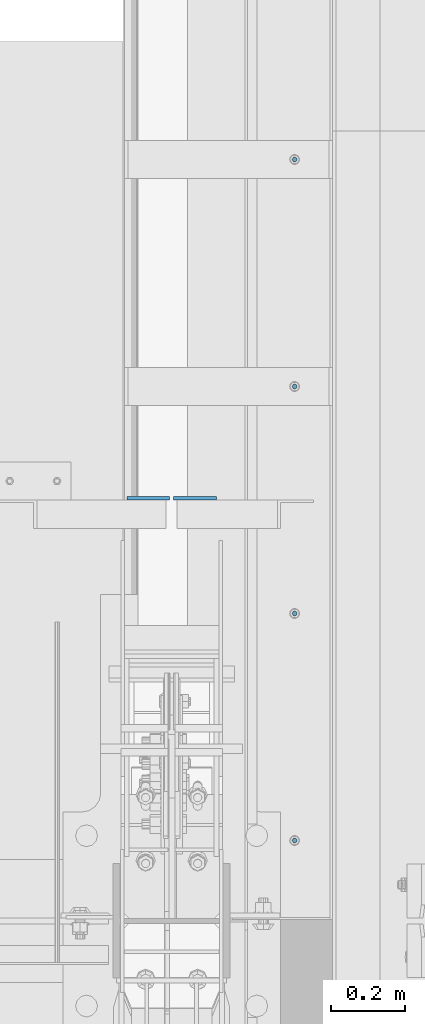
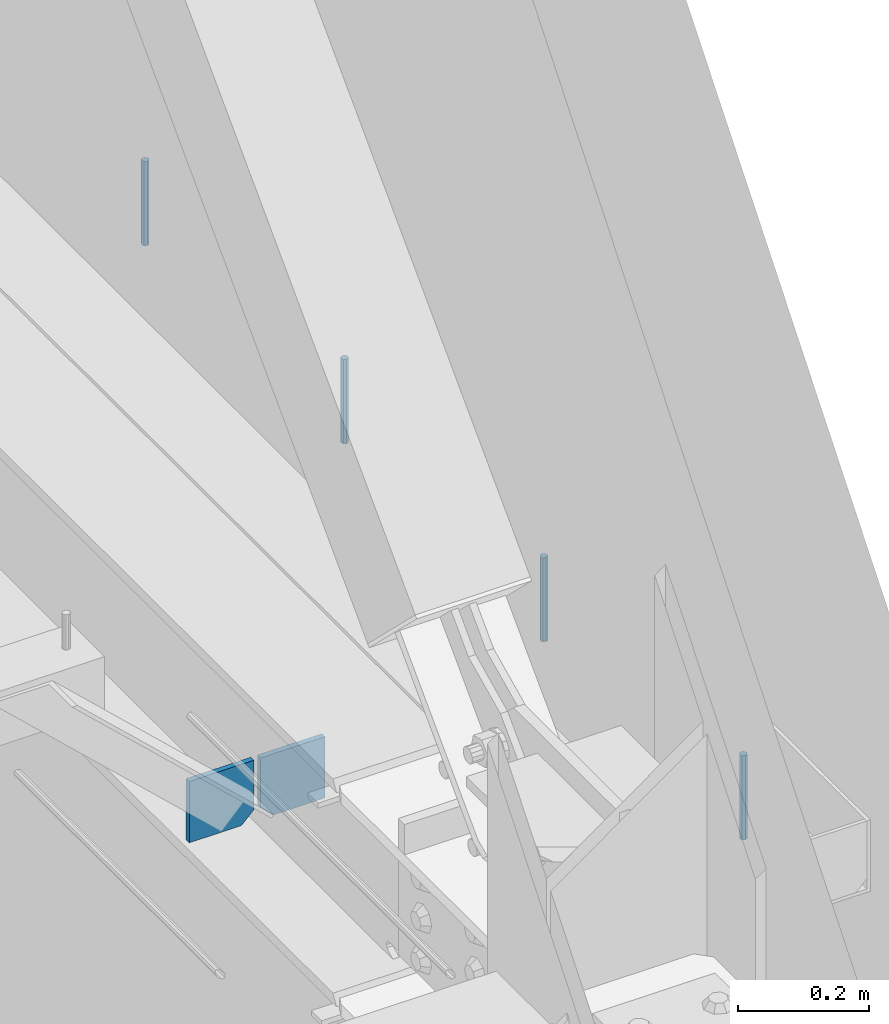
# One storey, part 409 of 1179: 6 columns, 1 element without a shape of its own.
"""IFC2X3 building model written with IfcOpenShell, lengths in millimetres."""

from ifc_helpers import new_model, si_unit, frame, origin_with_axes, place, context, subcontext, project, spatial, faceted_brep, material, type_object, element, aggregate, save


model = new_model("IFC2X3")

# Units and contexts
model_context = context("Model", 3, precision=1e-05, world=origin_with_axes())
body_context = subcontext(model_context, "Body", "Model", "MODEL_VIEW")
ifc_project = project(units=[si_unit("LENGTHUNIT", "METRE", prefix="MILLI"), si_unit("AREAUNIT", "SQUARE_METRE"), si_unit("VOLUMEUNIT", "CUBIC_METRE"), si_unit("MASSUNIT", "GRAM", prefix="KILO"), si_unit("TIMEUNIT", "SECOND"), si_unit("PLANEANGLEUNIT", "RADIAN"), si_unit("SOLIDANGLEUNIT", "STERADIAN"), si_unit("THERMODYNAMICTEMPERATUREUNIT", "DEGREE_CELSIUS"), si_unit("LUMINOUSINTENSITYUNIT", "LUMEN")], contexts=[model_context])

# Site, building, storey
site_placement = place(None, origin_with_axes())
site = spatial("IfcSite", under=ifc_project, at=site_placement, CompositionType="ELEMENT")
building_placement = place(site_placement, origin_with_axes())
building = spatial("IfcBuilding", under=site, at=building_placement, Name="Undefined", CompositionType="ELEMENT")
storey_placement = place(building_placement, origin_with_axes())
storey = spatial("IfcBuildingStorey", under=building, at=storey_placement, Name="Undefined", CompositionType="ELEMENT", Elevation=0.0)

# Assembly, columns
assembly_placement = place(storey_placement, origin_with_axes())
assembly = element("IfcElementAssembly", 1, at=assembly_placement, inside=storey, Name="BEAM", AssemblyPlace="NOTDEFINED", PredefinedType="RIGID_FRAME")
ifc_material_1 = material(Name="STEEL/A36")
column_type_1 = type_object("IfcColumnType", PredefinedType="NOTDEFINED")
column_1_placement = place(assembly_placement, frame((24245.09375, 12615.8625, 3702.05), z_axis=(1.0, 0.0, 0.0), x_axis=(0.0, 0.0, 1.0)))
column_1 = element("IfcColumn", 2, at=column_1_placement, type_object=column_type_1, material=ifc_material_1, Name="PLATE", context=body_context, shape_type="Brep", body=[
    faceted_brep([(22.2250000000004, 4.76250000000073, 57.1500000000015), (0.0, 4.76250000000073, 34.9249999999993), (0.0, -4.76250000000073, 34.9249999999993), (22.2250000000004, -4.76250000000073, 57.1500000000015), (114.300000000001, 4.76250000000073, 57.1500000000015), (114.300000000001, 4.76250000000073, -57.1500000000015), (0.0, 4.76250000000073, -57.1500000000015), (114.300000000001, -4.76250000000073, 57.1500000000015), (0.0, -4.76250000000073, -57.1500000000015), (114.300000000001, -4.76250000000073, -57.1500000000015)], [[[0, 1, 2, 3]], [[4, 5, 6, 1, 0]], [[7, 4, 0, 3]], [[8, 9, 7, 3, 2]], [[8, 6, 5, 9]], [[7, 9, 5, 4]], [[6, 8, 2, 1]]]),
])
column_2_placement = place(assembly_placement, frame((24370.50625, 12615.8625, 3702.05), z_axis=(-1.0, 0.0, 0.0), x_axis=(0.0, 0.0, 1.0)))
column_2 = element("IfcColumn", 3, at=column_2_placement, type_object=column_type_1, material=ifc_material_1, Name="PLATE", context=body_context, shape_type="Brep", body=[
    faceted_brep([(22.2250000000004, 4.76250000000073, 57.1500000000015), (0.0, 4.76250000000073, 34.9249999999993), (0.0, -4.76250000000073, 34.9249999999993), (22.2250000000004, -4.76250000000073, 57.1500000000015), (114.300000000001, 4.76250000000073, 57.1500000000015), (114.300000000001, 4.76250000000073, -57.1500000000015), (0.0, 4.76250000000073, -57.1500000000015), (114.300000000001, -4.76250000000073, 57.1500000000015), (0.0, -4.76250000000073, -57.1500000000015), (114.300000000001, -4.76250000000073, -57.1500000000015)], [[[0, 1, 2, 3]], [[4, 5, 6, 1, 0]], [[7, 4, 0, 3]], [[8, 9, 7, 3, 2]], [[8, 6, 5, 9]], [[7, 9, 5, 4]], [[6, 8, 2, 1]]]),
])
ifc_material_2 = material(Name="STEEL/A307")
column_type_2 = type_object("IfcColumnType", PredefinedType="NOTDEFINED")
column_3_placement = place(assembly_placement, frame((24638.0, 13525.5, 4108.45), z_axis=(0.0, 1.0, 0.0), x_axis=(0.0, 0.0, 1.0)))
column_3 = element("IfcColumn", 4, at=column_3_placement, type_object=column_type_2, material=ifc_material_2, Name="THREADED ROD", context=body_context, shape_type="Brep", body=[
    faceted_brep([(0.0, -6.34999999999854, 0.0), (0.0, -4.49012806053361, -4.49012806053452), (157.162499999999, -4.49012806053361, -4.49012806053361), (157.162499999999, -6.34999999999854, 0.0), (0.0, 0.0, -6.34999999999991), (157.162499999999, 0.0, -6.34999999999854), (0.0, 4.49012806053361, -4.49012806053452), (157.162499999999, 4.49012806053361, -4.49012806053361), (0.0, 6.34999999999854, 0.0), (157.162499999999, 6.34999999999854, 0.0), (0.0, 4.49012806053361, 4.49012806053452), (157.162499999999, 4.49012806053361, 4.49012806053361), (0.0, 0.0, 6.34999999999991), (157.162499999999, 0.0, 6.34999999999854), (0.0, -4.49012806053361, 4.49012806053452), (157.162499999999, -4.49012806053361, 4.49012806053361)], [[[0, 1, 2, 3]], [[1, 4, 5, 2]], [[4, 6, 7, 5]], [[6, 8, 9, 7]], [[8, 10, 11, 9]], [[10, 12, 13, 11]], [[12, 14, 15, 13]], [[14, 0, 3, 15]], [[5, 7, 9, 11, 13, 15, 3, 2]], [[14, 12, 10, 8, 6, 4, 1, 0]]]),
])
column_4_placement = place(assembly_placement, frame((24638.0, 12915.9, 4108.45), z_axis=(0.0, 1.0, 0.0), x_axis=(0.0, 0.0, 1.0)))
column_4 = element("IfcColumn", 5, at=column_4_placement, type_object=column_type_2, material=ifc_material_2, Name="THREADED ROD", context=body_context, shape_type="Brep", body=[
    faceted_brep([(0.0, -6.34999999999854, 0.0), (0.0, -4.49012806053361, -4.49012806053452), (157.162499999999, -4.49012806053361, -4.49012806053361), (157.162499999999, -6.34999999999854, 0.0), (0.0, 0.0, -6.34999999999991), (157.162499999999, 0.0, -6.34999999999854), (0.0, 4.49012806053361, -4.49012806053452), (157.162499999999, 4.49012806053361, -4.49012806053361), (0.0, 6.34999999999854, 0.0), (157.162499999999, 6.34999999999854, 0.0), (0.0, 4.49012806053361, 4.49012806053452), (157.162499999999, 4.49012806053361, 4.49012806053361), (0.0, 0.0, 6.34999999999991), (157.162499999999, 0.0, 6.34999999999854), (0.0, -4.49012806053361, 4.49012806053452), (157.162499999999, -4.49012806053361, 4.49012806053361)], [[[0, 1, 2, 3]], [[1, 4, 5, 2]], [[4, 6, 7, 5]], [[6, 8, 9, 7]], [[8, 10, 11, 9]], [[10, 12, 13, 11]], [[12, 14, 15, 13]], [[14, 0, 3, 15]], [[5, 7, 9, 11, 13, 15, 3, 2]], [[14, 12, 10, 8, 6, 4, 1, 0]]]),
])
column_5_placement = place(assembly_placement, frame((24638.0, 12306.3, 4108.45), z_axis=(0.0, 1.0, 0.0), x_axis=(0.0, 0.0, 1.0)))
column_5 = element("IfcColumn", 6, at=column_5_placement, type_object=column_type_2, material=ifc_material_2, Name="THREADED ROD", context=body_context, shape_type="Brep", body=[
    faceted_brep([(0.0, -6.34999999999854, 0.0), (0.0, -4.49012806053361, -4.49012806053452), (157.162499999999, -4.49012806053361, -4.49012806053361), (157.162499999999, -6.34999999999854, 0.0), (0.0, 0.0, -6.34999999999991), (157.162499999999, 0.0, -6.34999999999854), (0.0, 4.49012806053361, -4.49012806053452), (157.162499999999, 4.49012806053361, -4.49012806053361), (0.0, 6.34999999999854, 0.0), (157.162499999999, 6.34999999999854, 0.0), (0.0, 4.49012806053361, 4.49012806053452), (157.162499999999, 4.49012806053361, 4.49012806053361), (0.0, 0.0, 6.34999999999991), (157.162499999999, 0.0, 6.34999999999854), (0.0, -4.49012806053361, 4.49012806053452), (157.162499999999, -4.49012806053361, 4.49012806053361)], [[[0, 1, 2, 3]], [[1, 4, 5, 2]], [[4, 6, 7, 5]], [[6, 8, 9, 7]], [[8, 10, 11, 9]], [[10, 12, 13, 11]], [[12, 14, 15, 13]], [[14, 0, 3, 15]], [[5, 7, 9, 11, 13, 15, 3, 2]], [[14, 12, 10, 8, 6, 4, 1, 0]]]),
])
column_6_placement = place(assembly_placement, frame((24638.0, 11696.7, 4108.45), z_axis=(0.0, 1.0, 0.0), x_axis=(0.0, 0.0, 1.0)))
column_6 = element("IfcColumn", 7, at=column_6_placement, type_object=column_type_2, material=ifc_material_2, Name="THREADED ROD", context=body_context, shape_type="Brep", body=[
    faceted_brep([(0.0, -6.34999999999854, 0.0), (0.0, -4.49012806053361, -4.49012806053452), (157.162499999999, -4.49012806053361, -4.49012806053361), (157.162499999999, -6.34999999999854, 0.0), (0.0, 0.0, -6.34999999999991), (157.162499999999, 0.0, -6.34999999999854), (0.0, 4.49012806053361, -4.49012806053452), (157.162499999999, 4.49012806053361, -4.49012806053361), (0.0, 6.34999999999854, 0.0), (157.162499999999, 6.34999999999854, 0.0), (0.0, 4.49012806053361, 4.49012806053452), (157.162499999999, 4.49012806053361, 4.49012806053361), (0.0, 0.0, 6.34999999999991), (157.162499999999, 0.0, 6.34999999999854), (0.0, -4.49012806053361, 4.49012806053452), (157.162499999999, -4.49012806053361, 4.49012806053361)], [[[0, 1, 2, 3]], [[1, 4, 5, 2]], [[4, 6, 7, 5]], [[6, 8, 9, 7]], [[8, 10, 11, 9]], [[10, 12, 13, 11]], [[12, 14, 15, 13]], [[14, 0, 3, 15]], [[5, 7, 9, 11, 13, 15, 3, 2]], [[14, 12, 10, 8, 6, 4, 1, 0]]]),
])
aggregate(assembly, [column_3, column_4, column_5, column_6, column_1, column_2])

save(model, "model.ifc")
